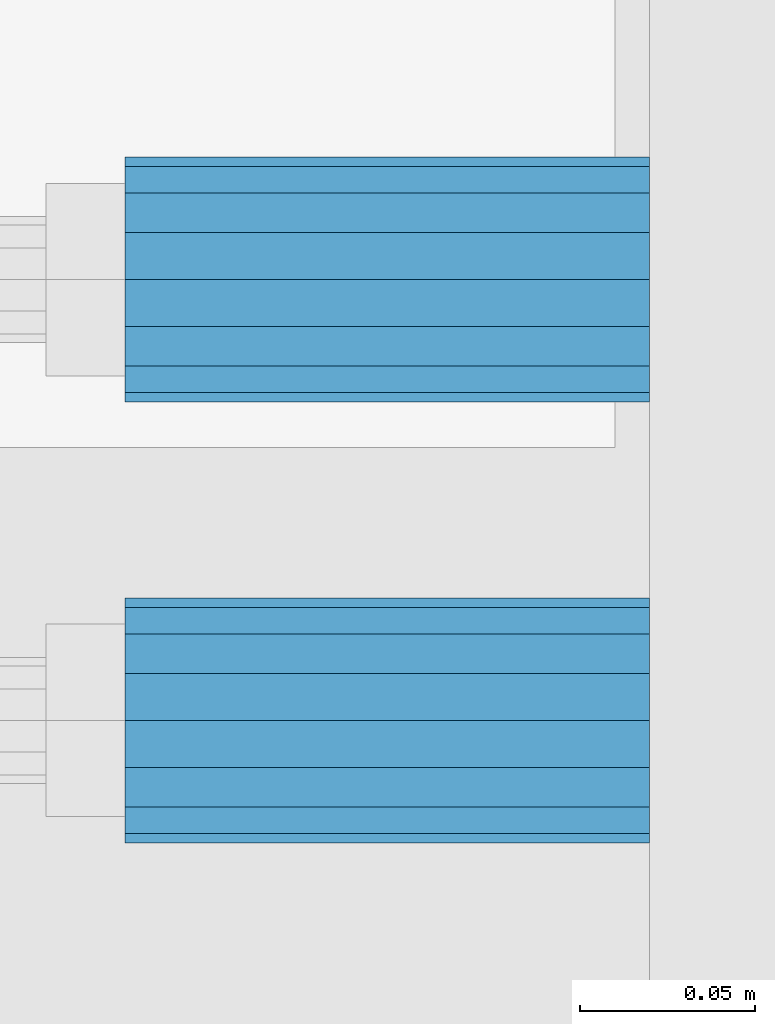
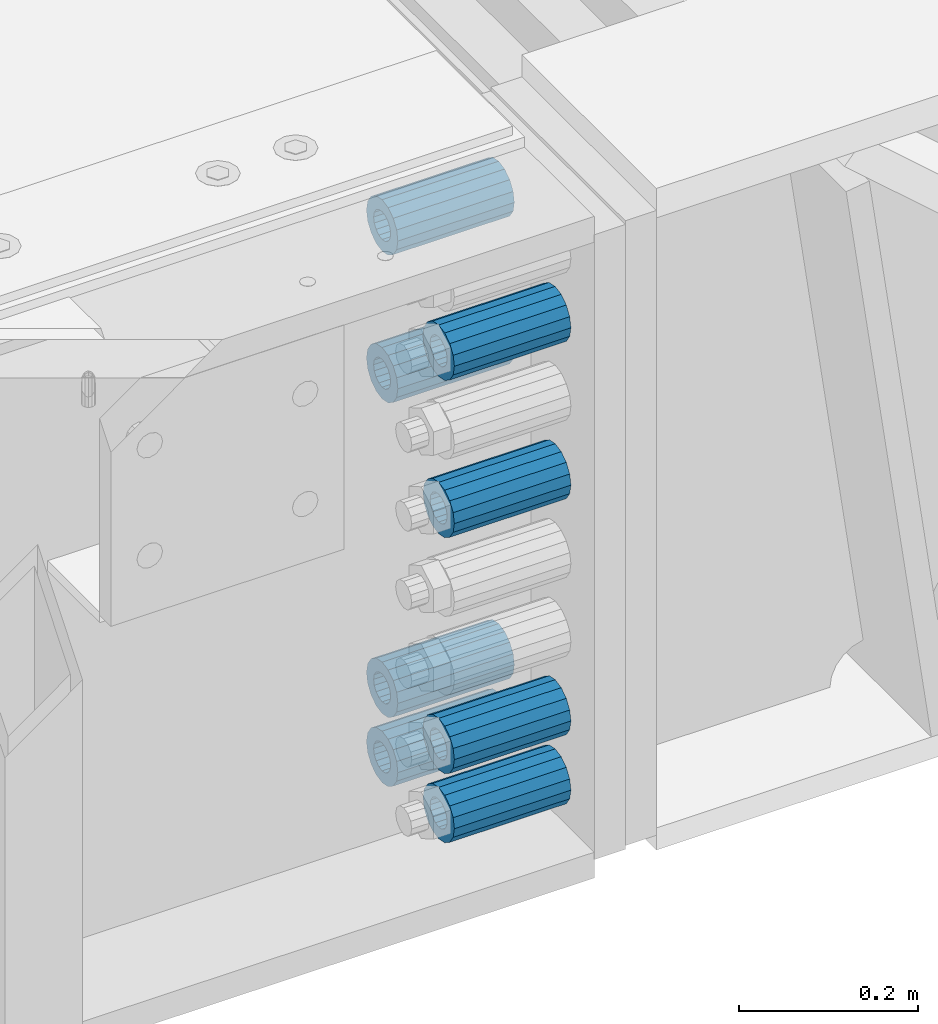
# One storey, part 158 of 242: 8 beams.
"""IFC2X3 building model written with IfcOpenShell, lengths in millimetres."""

from ifc_helpers import new_model, si_unit, frame, origin_with_axes, place, context, subcontext, project, spatial, faceted_brep, material, type_object, element, save


model = new_model("IFC2X3")

# Units and contexts
model_context = context("Model", 3, precision=1e-05, world=origin_with_axes())
body_context = subcontext(model_context, "Body", "Model", "MODEL_VIEW")
ifc_project = project(units=[si_unit("LENGTHUNIT", "METRE", prefix="MILLI"), si_unit("AREAUNIT", "SQUARE_METRE"), si_unit("VOLUMEUNIT", "CUBIC_METRE"), si_unit("MASSUNIT", "GRAM", prefix="KILO"), si_unit("TIMEUNIT", "SECOND"), si_unit("PLANEANGLEUNIT", "RADIAN"), si_unit("SOLIDANGLEUNIT", "STERADIAN"), si_unit("THERMODYNAMICTEMPERATUREUNIT", "DEGREE_CELSIUS"), si_unit("LUMINOUSINTENSITYUNIT", "LUMEN")], contexts=[model_context])

# Site, building, storey
site_placement = place(None, origin_with_axes())
site = spatial("IfcSite", under=ifc_project, at=site_placement, CompositionType="ELEMENT")
building_placement = place(site_placement, origin_with_axes())
building = spatial("IfcBuilding", under=site, at=building_placement, Name="Standard", CompositionType="ELEMENT")
storey_placement = place(building_placement, origin_with_axes())
storey = spatial("IfcBuildingStorey", under=building, at=storey_placement, Name="Undefined", CompositionType="ELEMENT", Elevation=0.0)

# Beams
ifc_material = material()
beam_type = type_object("IfcBeamType", PredefinedType="NOTDEFINED")
beam_1_placement = place(storey_placement, frame((-22210.0, -23937.0, -290.0), z_axis=(0.0, 0.0, 1.0), x_axis=(1.0, 0.0, 0.0)))
element("IfcBeam", 1, at=beam_1_placement, inside=storey, type_object=beam_type, material=ifc_material, context=body_context, shape_type="Brep", body=[
    faceted_brep([(1.33248249767348e-07, -19.0000000004493, -6.26823748461902e-09), (0.0, -17.5537111177146, 7.27098521493673), (150.0, -17.5537111177146, 7.27098521493673), (150.0, -19.0, 0.0), (0.0, -13.4350288425449, 13.4350288425444), (150.0, -13.4350288425449, 13.4350288425444), (0.0, -7.27098521493826, 17.5537111177144), (150.0, -7.27098521493826, 17.5537111177144), (-6.29370333626866e-09, -4.49290382675827e-10, 18.9999999937318), (150.0, 0.0, 19.0), (0.0, 7.27098521493826, 17.5537111177144), (150.0, 7.27098521493826, 17.5537111177144), (0.0, 13.4350288425449, 13.4350288425444), (150.0, 13.4350288425449, 13.4350288425444), (0.0, 17.5537111177146, 7.2709852149367), (150.0, 17.5537111177146, 7.2709852149367), (-1.31243723444641e-07, 18.9999999995507, -6.26823748461902e-09), (150.0, 19.0, 0.0), (0.0, 17.5537111177146, -7.2709852149367), (150.0, 17.5537111177146, -7.2709852149367), (0.0, 13.4350288425449, -13.4350288425444), (150.0, 13.4350288425449, -13.4350288425444), (0.0, 7.27098521493826, -17.5537111177144), (150.0, 7.27098521493826, -17.5537111177144), (8.2982296589762e-09, -4.49290382675827e-10, -19.0000000062719), (150.0, 0.0, -19.0), (0.0, -7.27098521493826, -17.5537111177144), (150.0, -7.27098521493826, -17.5537111177144), (0.0, -13.4350288425449, -13.4350288425444), (150.0, -13.4350288425449, -13.4350288425444), (0.0, -17.5537111177146, -7.2709852149367), (150.0, -17.5537111177146, -7.2709852149367), (-3.63797880709171e-12, -35.0, 0.0), (-3.63797880709171e-12, -32.335783637895, -13.3939201327812), (150.0, -32.3357836378964, -13.3939201327782), (150.0, -35.0, 0.0), (0.0, -24.7487373415292, -24.7487373415315), (150.0, -24.7487373415279, -24.7487373415292), (0.0, -13.3939201327782, -32.3357836378964), (150.0, -13.3939201327776, -32.335783637895), (0.0, 0.0, -35.0000000000036), (150.0, 0.0, -35.0), (0.0, 13.3939201327782, -32.3357836378964), (150.0, 13.3939201327776, -32.335783637895), (0.0, 24.7487373415292, -24.7487373415315), (150.0, 24.7487373415279, -24.7487373415292), (-3.63797880709171e-12, 32.335783637895, -13.3939201327812), (150.0, 32.3357836378964, -13.3939201327781), (-3.63797880709171e-12, 35.0, 0.0), (150.0, 35.0, 0.0), (-7.27595761418343e-12, 32.335783637895, 13.3939201327739), (150.0, 32.3357836378964, 13.3939201327781), (-7.27595761418343e-12, 24.7487373415292, 24.7487373415242), (150.0, 24.7487373415279, 24.7487373415292), (-7.27595761418343e-12, 13.3939201327781, 32.3357836378891), (150.0, 13.3939201327776, 32.335783637895), (-1.09139364212751e-11, 0.0, 34.9999999999964), (150.0, 0.0, 35.0), (-7.27595761418343e-12, -13.3939201327781, 32.3357836378891), (150.0, -13.3939201327776, 32.335783637895), (-7.27595761418343e-12, -24.7487373415292, 24.7487373415242), (150.0, -24.7487373415279, 24.7487373415292), (-7.27595761418343e-12, -32.335783637895, 13.3939201327739), (150.0, -32.3357836378964, 13.3939201327781)], [[[0, 1, 2, 3]], [[1, 4, 5, 2]], [[4, 6, 7, 5]], [[6, 8, 9, 7]], [[8, 10, 11, 9]], [[10, 12, 13, 11]], [[12, 14, 15, 13]], [[14, 16, 17, 15]], [[16, 18, 19, 17]], [[18, 20, 21, 19]], [[20, 22, 23, 21]], [[22, 24, 25, 23]], [[24, 26, 27, 25]], [[26, 28, 29, 27]], [[28, 30, 31, 29]], [[30, 0, 3, 31]], [[32, 33, 34, 35]], [[33, 36, 37, 34]], [[36, 38, 39, 37]], [[38, 40, 41, 39]], [[40, 42, 43, 41]], [[42, 44, 45, 43]], [[44, 46, 47, 45]], [[46, 48, 49, 47]], [[48, 50, 51, 49]], [[50, 52, 53, 51]], [[52, 54, 55, 53]], [[54, 56, 57, 55]], [[56, 58, 59, 57]], [[58, 60, 61, 59]], [[60, 62, 63, 61]], [[62, 32, 35, 63]], [[37, 39, 41, 43, 45, 47, 49, 51, 53, 55, 57, 59, 61, 63, 35, 34], [5, 7, 9, 11, 13, 15, 17, 19, 21, 23, 25, 27, 29, 31, 3, 2]], [[62, 60, 58, 56, 54, 52, 50, 48, 46, 44, 42, 40, 38, 36, 33, 32], [30, 28, 26, 24, 22, 20, 18, 16, 14, 12, 10, 8, 6, 4, 1, 0]]]),
])
beam_2_placement = place(storey_placement, frame((-22210.0, -23937.0, -718.0), z_axis=(0.0, 0.0, 1.0), x_axis=(1.0, 0.0, 0.0)))
element("IfcBeam", 2, at=beam_2_placement, inside=storey, type_object=beam_type, material=ifc_material, context=body_context, shape_type="Brep", body=[
    faceted_brep([(1.33248249767348e-07, -19.0000000004493, -6.26823748461902e-09), (0.0, -17.5537111177146, 7.27098521493673), (150.0, -17.5537111177146, 7.27098521493673), (150.0, -19.0, 0.0), (0.0, -13.4350288425449, 13.4350288425444), (150.0, -13.4350288425449, 13.4350288425444), (0.0, -7.27098521493826, 17.5537111177144), (150.0, -7.27098521493826, 17.5537111177144), (-6.29370333626866e-09, -4.49290382675827e-10, 18.9999999937318), (150.0, 0.0, 19.0), (0.0, 7.27098521493826, 17.5537111177144), (150.0, 7.27098521493826, 17.5537111177144), (0.0, 13.4350288425449, 13.4350288425444), (150.0, 13.4350288425449, 13.4350288425444), (0.0, 17.5537111177146, 7.2709852149367), (150.0, 17.5537111177146, 7.2709852149367), (-1.31243723444641e-07, 18.9999999995507, -6.26823748461902e-09), (150.0, 19.0, 0.0), (0.0, 17.5537111177146, -7.2709852149367), (150.0, 17.5537111177146, -7.2709852149367), (0.0, 13.4350288425449, -13.4350288425444), (150.0, 13.4350288425449, -13.4350288425444), (0.0, 7.27098521493826, -17.5537111177144), (150.0, 7.27098521493826, -17.5537111177144), (8.2982296589762e-09, -4.49290382675827e-10, -19.0000000062719), (150.0, 0.0, -19.0), (0.0, -7.27098521493826, -17.5537111177144), (150.0, -7.27098521493826, -17.5537111177144), (0.0, -13.4350288425449, -13.4350288425444), (150.0, -13.4350288425449, -13.4350288425444), (0.0, -17.5537111177146, -7.2709852149367), (150.0, -17.5537111177146, -7.2709852149367), (-3.63797880709171e-12, -35.0, 0.0), (-3.63797880709171e-12, -32.335783637895, -13.3939201327812), (150.0, -32.3357836378964, -13.3939201327782), (150.0, -35.0, 0.0), (0.0, -24.7487373415292, -24.7487373415315), (150.0, -24.7487373415279, -24.7487373415292), (0.0, -13.3939201327782, -32.3357836378964), (150.0, -13.3939201327776, -32.335783637895), (0.0, 0.0, -35.0000000000036), (150.0, 0.0, -35.0), (0.0, 13.3939201327782, -32.3357836378964), (150.0, 13.3939201327776, -32.335783637895), (0.0, 24.7487373415292, -24.7487373415315), (150.0, 24.7487373415279, -24.7487373415292), (-3.63797880709171e-12, 32.335783637895, -13.3939201327812), (150.0, 32.3357836378964, -13.3939201327781), (-3.63797880709171e-12, 35.0, 0.0), (150.0, 35.0, 0.0), (-7.27595761418343e-12, 32.335783637895, 13.3939201327739), (150.0, 32.3357836378964, 13.3939201327781), (-7.27595761418343e-12, 24.7487373415292, 24.7487373415242), (150.0, 24.7487373415279, 24.7487373415292), (-7.27595761418343e-12, 13.3939201327781, 32.3357836378891), (150.0, 13.3939201327776, 32.335783637895), (-1.09139364212751e-11, 0.0, 34.9999999999964), (150.0, 0.0, 35.0), (-7.27595761418343e-12, -13.3939201327781, 32.3357836378891), (150.0, -13.3939201327776, 32.335783637895), (-7.27595761418343e-12, -24.7487373415292, 24.7487373415242), (150.0, -24.7487373415279, 24.7487373415292), (-7.27595761418343e-12, -32.335783637895, 13.3939201327739), (150.0, -32.3357836378964, 13.3939201327781)], [[[0, 1, 2, 3]], [[1, 4, 5, 2]], [[4, 6, 7, 5]], [[6, 8, 9, 7]], [[8, 10, 11, 9]], [[10, 12, 13, 11]], [[12, 14, 15, 13]], [[14, 16, 17, 15]], [[16, 18, 19, 17]], [[18, 20, 21, 19]], [[20, 22, 23, 21]], [[22, 24, 25, 23]], [[24, 26, 27, 25]], [[26, 28, 29, 27]], [[28, 30, 31, 29]], [[30, 0, 3, 31]], [[32, 33, 34, 35]], [[33, 36, 37, 34]], [[36, 38, 39, 37]], [[38, 40, 41, 39]], [[40, 42, 43, 41]], [[42, 44, 45, 43]], [[44, 46, 47, 45]], [[46, 48, 49, 47]], [[48, 50, 51, 49]], [[50, 52, 53, 51]], [[52, 54, 55, 53]], [[54, 56, 57, 55]], [[56, 58, 59, 57]], [[58, 60, 61, 59]], [[60, 62, 63, 61]], [[62, 32, 35, 63]], [[37, 39, 41, 43, 45, 47, 49, 51, 53, 55, 57, 59, 61, 63, 35, 34], [5, 7, 9, 11, 13, 15, 17, 19, 21, 23, 25, 27, 29, 31, 3, 2]], [[62, 60, 58, 56, 54, 52, 50, 48, 46, 44, 42, 40, 38, 36, 33, 32], [30, 28, 26, 24, 22, 20, 18, 16, 14, 12, 10, 8, 6, 4, 1, 0]]]),
])
beam_3_placement = place(storey_placement, frame((-22210.0, -24063.0, -397.0), z_axis=(0.0, 0.0, 1.0), x_axis=(1.0, 0.0, 0.0)))
element("IfcBeam", 3, at=beam_3_placement, inside=storey, type_object=beam_type, material=ifc_material, context=body_context, shape_type="Brep", body=[
    faceted_brep([(1.33248249767348e-07, -19.0000000004493, -6.26823748461902e-09), (0.0, -17.5537111177146, 7.27098521493673), (150.0, -17.5537111177146, 7.27098521493673), (150.0, -19.0, 0.0), (0.0, -13.4350288425449, 13.4350288425444), (150.0, -13.4350288425449, 13.4350288425444), (0.0, -7.27098521493826, 17.5537111177144), (150.0, -7.27098521493826, 17.5537111177144), (-6.29370333626866e-09, -4.49290382675827e-10, 18.9999999937318), (150.0, 0.0, 19.0), (0.0, 7.27098521493826, 17.5537111177144), (150.0, 7.27098521493826, 17.5537111177144), (0.0, 13.4350288425449, 13.4350288425444), (150.0, 13.4350288425449, 13.4350288425444), (0.0, 17.5537111177146, 7.2709852149367), (150.0, 17.5537111177146, 7.2709852149367), (-1.31243723444641e-07, 18.9999999995507, -6.26823748461902e-09), (150.0, 19.0, 0.0), (0.0, 17.5537111177146, -7.2709852149367), (150.0, 17.5537111177146, -7.2709852149367), (0.0, 13.4350288425449, -13.4350288425444), (150.0, 13.4350288425449, -13.4350288425444), (0.0, 7.27098521493826, -17.5537111177144), (150.0, 7.27098521493826, -17.5537111177144), (8.2982296589762e-09, -4.49290382675827e-10, -19.0000000062719), (150.0, 0.0, -19.0), (0.0, -7.27098521493826, -17.5537111177144), (150.0, -7.27098521493826, -17.5537111177144), (0.0, -13.4350288425449, -13.4350288425444), (150.0, -13.4350288425449, -13.4350288425444), (0.0, -17.5537111177146, -7.2709852149367), (150.0, -17.5537111177146, -7.2709852149367), (-3.63797880709171e-12, -35.0, 0.0), (-3.63797880709171e-12, -32.335783637895, -13.3939201327812), (150.0, -32.3357836378964, -13.3939201327782), (150.0, -35.0, 0.0), (0.0, -24.7487373415292, -24.7487373415315), (150.0, -24.7487373415279, -24.7487373415292), (0.0, -13.3939201327782, -32.3357836378964), (150.0, -13.3939201327776, -32.335783637895), (0.0, 0.0, -35.0000000000036), (150.0, 0.0, -35.0), (0.0, 13.3939201327782, -32.3357836378964), (150.0, 13.3939201327776, -32.335783637895), (0.0, 24.7487373415292, -24.7487373415315), (150.0, 24.7487373415279, -24.7487373415292), (-3.63797880709171e-12, 32.335783637895, -13.3939201327812), (150.0, 32.3357836378964, -13.3939201327781), (-3.63797880709171e-12, 35.0, 0.0), (150.0, 35.0, 0.0), (-7.27595761418343e-12, 32.335783637895, 13.3939201327739), (150.0, 32.3357836378964, 13.3939201327781), (-7.27595761418343e-12, 24.7487373415292, 24.7487373415242), (150.0, 24.7487373415279, 24.7487373415292), (-7.27595761418343e-12, 13.3939201327781, 32.3357836378891), (150.0, 13.3939201327776, 32.335783637895), (-1.09139364212751e-11, 0.0, 34.9999999999964), (150.0, 0.0, 35.0), (-7.27595761418343e-12, -13.3939201327781, 32.3357836378891), (150.0, -13.3939201327776, 32.335783637895), (-7.27595761418343e-12, -24.7487373415292, 24.7487373415242), (150.0, -24.7487373415279, 24.7487373415292), (-7.27595761418343e-12, -32.335783637895, 13.3939201327739), (150.0, -32.3357836378964, 13.3939201327781)], [[[0, 1, 2, 3]], [[1, 4, 5, 2]], [[4, 6, 7, 5]], [[6, 8, 9, 7]], [[8, 10, 11, 9]], [[10, 12, 13, 11]], [[12, 14, 15, 13]], [[14, 16, 17, 15]], [[16, 18, 19, 17]], [[18, 20, 21, 19]], [[20, 22, 23, 21]], [[22, 24, 25, 23]], [[24, 26, 27, 25]], [[26, 28, 29, 27]], [[28, 30, 31, 29]], [[30, 0, 3, 31]], [[32, 33, 34, 35]], [[33, 36, 37, 34]], [[36, 38, 39, 37]], [[38, 40, 41, 39]], [[40, 42, 43, 41]], [[42, 44, 45, 43]], [[44, 46, 47, 45]], [[46, 48, 49, 47]], [[48, 50, 51, 49]], [[50, 52, 53, 51]], [[52, 54, 55, 53]], [[54, 56, 57, 55]], [[56, 58, 59, 57]], [[58, 60, 61, 59]], [[60, 62, 63, 61]], [[62, 32, 35, 63]], [[37, 39, 41, 43, 45, 47, 49, 51, 53, 55, 57, 59, 61, 63, 35, 34], [5, 7, 9, 11, 13, 15, 17, 19, 21, 23, 25, 27, 29, 31, 3, 2]], [[62, 60, 58, 56, 54, 52, 50, 48, 46, 44, 42, 40, 38, 36, 33, 32], [30, 28, 26, 24, 22, 20, 18, 16, 14, 12, 10, 8, 6, 4, 1, 0]]]),
])
beam_4_placement = place(storey_placement, frame((-22210.0, -23937.0, -89.0000000000001), z_axis=(0.0, 0.0, 1.0), x_axis=(1.0, 0.0, 0.0)))
element("IfcBeam", 4, at=beam_4_placement, inside=storey, type_object=beam_type, material=ifc_material, context=body_context, shape_type="Brep", body=[
    faceted_brep([(1.33248249767348e-07, -19.0000000004493, -6.26823748461902e-09), (0.0, -17.5537111177146, 7.27098521493673), (150.0, -17.5537111177146, 7.27098521493673), (150.0, -19.0, 0.0), (0.0, -13.4350288425449, 13.4350288425444), (150.0, -13.4350288425449, 13.4350288425444), (0.0, -7.27098521493826, 17.5537111177144), (150.0, -7.27098521493826, 17.5537111177144), (-6.29370333626866e-09, -4.49290382675827e-10, 18.9999999937318), (150.0, 0.0, 19.0), (0.0, 7.27098521493826, 17.5537111177144), (150.0, 7.27098521493826, 17.5537111177144), (0.0, 13.4350288425449, 13.4350288425444), (150.0, 13.4350288425449, 13.4350288425444), (0.0, 17.5537111177146, 7.2709852149367), (150.0, 17.5537111177146, 7.2709852149367), (-1.31243723444641e-07, 18.9999999995507, -6.26823748461902e-09), (150.0, 19.0, 0.0), (0.0, 17.5537111177146, -7.2709852149367), (150.0, 17.5537111177146, -7.2709852149367), (0.0, 13.4350288425449, -13.4350288425444), (150.0, 13.4350288425449, -13.4350288425444), (0.0, 7.27098521493826, -17.5537111177144), (150.0, 7.27098521493826, -17.5537111177144), (8.2982296589762e-09, -4.49290382675827e-10, -19.0000000062719), (150.0, 0.0, -19.0), (0.0, -7.27098521493826, -17.5537111177144), (150.0, -7.27098521493826, -17.5537111177144), (0.0, -13.4350288425449, -13.4350288425444), (150.0, -13.4350288425449, -13.4350288425444), (0.0, -17.5537111177146, -7.2709852149367), (150.0, -17.5537111177146, -7.2709852149367), (-3.63797880709171e-12, -35.0, 0.0), (-3.63797880709171e-12, -32.335783637895, -13.3939201327812), (150.0, -32.3357836378964, -13.3939201327782), (150.0, -35.0, 0.0), (0.0, -24.7487373415292, -24.7487373415315), (150.0, -24.7487373415279, -24.7487373415292), (0.0, -13.3939201327782, -32.3357836378964), (150.0, -13.3939201327776, -32.335783637895), (0.0, 0.0, -35.0000000000036), (150.0, 0.0, -35.0), (0.0, 13.3939201327782, -32.3357836378964), (150.0, 13.3939201327776, -32.335783637895), (0.0, 24.7487373415292, -24.7487373415315), (150.0, 24.7487373415279, -24.7487373415292), (-3.63797880709171e-12, 32.335783637895, -13.3939201327812), (150.0, 32.3357836378964, -13.3939201327781), (-3.63797880709171e-12, 35.0, 0.0), (150.0, 35.0, 0.0), (-7.27595761418343e-12, 32.335783637895, 13.3939201327739), (150.0, 32.3357836378964, 13.3939201327781), (-7.27595761418343e-12, 24.7487373415292, 24.7487373415242), (150.0, 24.7487373415279, 24.7487373415292), (-7.27595761418343e-12, 13.3939201327781, 32.3357836378891), (150.0, 13.3939201327776, 32.335783637895), (-1.09139364212751e-11, 0.0, 34.9999999999964), (150.0, 0.0, 35.0), (-7.27595761418343e-12, -13.3939201327781, 32.3357836378891), (150.0, -13.3939201327776, 32.335783637895), (-7.27595761418343e-12, -24.7487373415292, 24.7487373415242), (150.0, -24.7487373415279, 24.7487373415292), (-7.27595761418343e-12, -32.335783637895, 13.3939201327739), (150.0, -32.3357836378964, 13.3939201327781)], [[[0, 1, 2, 3]], [[1, 4, 5, 2]], [[4, 6, 7, 5]], [[6, 8, 9, 7]], [[8, 10, 11, 9]], [[10, 12, 13, 11]], [[12, 14, 15, 13]], [[14, 16, 17, 15]], [[16, 18, 19, 17]], [[18, 20, 21, 19]], [[20, 22, 23, 21]], [[22, 24, 25, 23]], [[24, 26, 27, 25]], [[26, 28, 29, 27]], [[28, 30, 31, 29]], [[30, 0, 3, 31]], [[32, 33, 34, 35]], [[33, 36, 37, 34]], [[36, 38, 39, 37]], [[38, 40, 41, 39]], [[40, 42, 43, 41]], [[42, 44, 45, 43]], [[44, 46, 47, 45]], [[46, 48, 49, 47]], [[48, 50, 51, 49]], [[50, 52, 53, 51]], [[52, 54, 55, 53]], [[54, 56, 57, 55]], [[56, 58, 59, 57]], [[58, 60, 61, 59]], [[60, 62, 63, 61]], [[62, 32, 35, 63]], [[37, 39, 41, 43, 45, 47, 49, 51, 53, 55, 57, 59, 61, 63, 35, 34], [5, 7, 9, 11, 13, 15, 17, 19, 21, 23, 25, 27, 29, 31, 3, 2]], [[62, 60, 58, 56, 54, 52, 50, 48, 46, 44, 42, 40, 38, 36, 33, 32], [30, 28, 26, 24, 22, 20, 18, 16, 14, 12, 10, 8, 6, 4, 1, 0]]]),
])
beam_5_placement = place(storey_placement, frame((-22210.0, -24063.0, -183.0), z_axis=(0.0, 0.0, 1.0), x_axis=(1.0, 0.0, 0.0)))
element("IfcBeam", 5, at=beam_5_placement, inside=storey, type_object=beam_type, material=ifc_material, context=body_context, shape_type="Brep", body=[
    faceted_brep([(1.33248249767348e-07, -19.0000000004493, -6.26823748461902e-09), (0.0, -17.5537111177146, 7.27098521493673), (150.0, -17.5537111177146, 7.27098521493673), (150.0, -19.0, 0.0), (0.0, -13.4350288425449, 13.4350288425444), (150.0, -13.4350288425449, 13.4350288425444), (0.0, -7.27098521493826, 17.5537111177144), (150.0, -7.27098521493826, 17.5537111177144), (-6.29370333626866e-09, -4.49290382675827e-10, 18.9999999937318), (150.0, 0.0, 19.0), (0.0, 7.27098521493826, 17.5537111177144), (150.0, 7.27098521493826, 17.5537111177144), (0.0, 13.4350288425449, 13.4350288425444), (150.0, 13.4350288425449, 13.4350288425444), (0.0, 17.5537111177146, 7.2709852149367), (150.0, 17.5537111177146, 7.2709852149367), (-1.31243723444641e-07, 18.9999999995507, -6.26823748461902e-09), (150.0, 19.0, 0.0), (0.0, 17.5537111177146, -7.2709852149367), (150.0, 17.5537111177146, -7.2709852149367), (0.0, 13.4350288425449, -13.4350288425444), (150.0, 13.4350288425449, -13.4350288425444), (0.0, 7.27098521493826, -17.5537111177144), (150.0, 7.27098521493826, -17.5537111177144), (8.2982296589762e-09, -4.49290382675827e-10, -19.0000000062719), (150.0, 0.0, -19.0), (0.0, -7.27098521493826, -17.5537111177144), (150.0, -7.27098521493826, -17.5537111177144), (0.0, -13.4350288425449, -13.4350288425444), (150.0, -13.4350288425449, -13.4350288425444), (0.0, -17.5537111177146, -7.2709852149367), (150.0, -17.5537111177146, -7.2709852149367), (-3.63797880709171e-12, -35.0, 0.0), (-3.63797880709171e-12, -32.335783637895, -13.3939201327812), (150.0, -32.3357836378964, -13.3939201327782), (150.0, -35.0, 0.0), (0.0, -24.7487373415292, -24.7487373415315), (150.0, -24.7487373415279, -24.7487373415292), (0.0, -13.3939201327782, -32.3357836378964), (150.0, -13.3939201327776, -32.335783637895), (0.0, 0.0, -35.0000000000036), (150.0, 0.0, -35.0), (0.0, 13.3939201327782, -32.3357836378964), (150.0, 13.3939201327776, -32.335783637895), (0.0, 24.7487373415292, -24.7487373415315), (150.0, 24.7487373415279, -24.7487373415292), (-3.63797880709171e-12, 32.335783637895, -13.3939201327812), (150.0, 32.3357836378964, -13.3939201327781), (-3.63797880709171e-12, 35.0, 0.0), (150.0, 35.0, 0.0), (-7.27595761418343e-12, 32.335783637895, 13.3939201327739), (150.0, 32.3357836378964, 13.3939201327781), (-7.27595761418343e-12, 24.7487373415292, 24.7487373415242), (150.0, 24.7487373415279, 24.7487373415292), (-7.27595761418343e-12, 13.3939201327781, 32.3357836378891), (150.0, 13.3939201327776, 32.335783637895), (-1.09139364212751e-11, 0.0, 34.9999999999964), (150.0, 0.0, 35.0), (-7.27595761418343e-12, -13.3939201327781, 32.3357836378891), (150.0, -13.3939201327776, 32.335783637895), (-7.27595761418343e-12, -24.7487373415292, 24.7487373415242), (150.0, -24.7487373415279, 24.7487373415292), (-7.27595761418343e-12, -32.335783637895, 13.3939201327739), (150.0, -32.3357836378964, 13.3939201327781)], [[[0, 1, 2, 3]], [[1, 4, 5, 2]], [[4, 6, 7, 5]], [[6, 8, 9, 7]], [[8, 10, 11, 9]], [[10, 12, 13, 11]], [[12, 14, 15, 13]], [[14, 16, 17, 15]], [[16, 18, 19, 17]], [[18, 20, 21, 19]], [[20, 22, 23, 21]], [[22, 24, 25, 23]], [[24, 26, 27, 25]], [[26, 28, 29, 27]], [[28, 30, 31, 29]], [[30, 0, 3, 31]], [[32, 33, 34, 35]], [[33, 36, 37, 34]], [[36, 38, 39, 37]], [[38, 40, 41, 39]], [[40, 42, 43, 41]], [[42, 44, 45, 43]], [[44, 46, 47, 45]], [[46, 48, 49, 47]], [[48, 50, 51, 49]], [[50, 52, 53, 51]], [[52, 54, 55, 53]], [[54, 56, 57, 55]], [[56, 58, 59, 57]], [[58, 60, 61, 59]], [[60, 62, 63, 61]], [[62, 32, 35, 63]], [[37, 39, 41, 43, 45, 47, 49, 51, 53, 55, 57, 59, 61, 63, 35, 34], [5, 7, 9, 11, 13, 15, 17, 19, 21, 23, 25, 27, 29, 31, 3, 2]], [[62, 60, 58, 56, 54, 52, 50, 48, 46, 44, 42, 40, 38, 36, 33, 32], [30, 28, 26, 24, 22, 20, 18, 16, 14, 12, 10, 8, 6, 4, 1, 0]]]),
])
beam_6_placement = place(storey_placement, frame((-22210.0, -24063.0, -718.0), z_axis=(0.0, 0.0, 1.0), x_axis=(1.0, 0.0, 0.0)))
element("IfcBeam", 6, at=beam_6_placement, inside=storey, type_object=beam_type, material=ifc_material, context=body_context, shape_type="Brep", body=[
    faceted_brep([(1.33248249767348e-07, -19.0000000004493, -6.26823748461902e-09), (0.0, -17.5537111177146, 7.27098521493673), (150.0, -17.5537111177146, 7.27098521493673), (150.0, -19.0, 0.0), (0.0, -13.4350288425449, 13.4350288425444), (150.0, -13.4350288425449, 13.4350288425444), (0.0, -7.27098521493826, 17.5537111177144), (150.0, -7.27098521493826, 17.5537111177144), (-6.29370333626866e-09, -4.49290382675827e-10, 18.9999999937318), (150.0, 0.0, 19.0), (0.0, 7.27098521493826, 17.5537111177144), (150.0, 7.27098521493826, 17.5537111177144), (0.0, 13.4350288425449, 13.4350288425444), (150.0, 13.4350288425449, 13.4350288425444), (0.0, 17.5537111177146, 7.2709852149367), (150.0, 17.5537111177146, 7.2709852149367), (-1.31243723444641e-07, 18.9999999995507, -6.26823748461902e-09), (150.0, 19.0, 0.0), (0.0, 17.5537111177146, -7.2709852149367), (150.0, 17.5537111177146, -7.2709852149367), (0.0, 13.4350288425449, -13.4350288425444), (150.0, 13.4350288425449, -13.4350288425444), (0.0, 7.27098521493826, -17.5537111177144), (150.0, 7.27098521493826, -17.5537111177144), (8.2982296589762e-09, -4.49290382675827e-10, -19.0000000062719), (150.0, 0.0, -19.0), (0.0, -7.27098521493826, -17.5537111177144), (150.0, -7.27098521493826, -17.5537111177144), (0.0, -13.4350288425449, -13.4350288425444), (150.0, -13.4350288425449, -13.4350288425444), (0.0, -17.5537111177146, -7.2709852149367), (150.0, -17.5537111177146, -7.2709852149367), (-3.63797880709171e-12, -35.0, 0.0), (-3.63797880709171e-12, -32.335783637895, -13.3939201327812), (150.0, -32.3357836378964, -13.3939201327782), (150.0, -35.0, 0.0), (0.0, -24.7487373415292, -24.7487373415315), (150.0, -24.7487373415279, -24.7487373415292), (0.0, -13.3939201327782, -32.3357836378964), (150.0, -13.3939201327776, -32.335783637895), (0.0, 0.0, -35.0000000000036), (150.0, 0.0, -35.0), (0.0, 13.3939201327782, -32.3357836378964), (150.0, 13.3939201327776, -32.335783637895), (0.0, 24.7487373415292, -24.7487373415315), (150.0, 24.7487373415279, -24.7487373415292), (-3.63797880709171e-12, 32.335783637895, -13.3939201327812), (150.0, 32.3357836378964, -13.3939201327781), (-3.63797880709171e-12, 35.0, 0.0), (150.0, 35.0, 0.0), (-7.27595761418343e-12, 32.335783637895, 13.3939201327739), (150.0, 32.3357836378964, 13.3939201327781), (-7.27595761418343e-12, 24.7487373415292, 24.7487373415242), (150.0, 24.7487373415279, 24.7487373415292), (-7.27595761418343e-12, 13.3939201327781, 32.3357836378891), (150.0, 13.3939201327776, 32.335783637895), (-1.09139364212751e-11, 0.0, 34.9999999999964), (150.0, 0.0, 35.0), (-7.27595761418343e-12, -13.3939201327781, 32.3357836378891), (150.0, -13.3939201327776, 32.335783637895), (-7.27595761418343e-12, -24.7487373415292, 24.7487373415242), (150.0, -24.7487373415279, 24.7487373415292), (-7.27595761418343e-12, -32.335783637895, 13.3939201327739), (150.0, -32.3357836378964, 13.3939201327781)], [[[0, 1, 2, 3]], [[1, 4, 5, 2]], [[4, 6, 7, 5]], [[6, 8, 9, 7]], [[8, 10, 11, 9]], [[10, 12, 13, 11]], [[12, 14, 15, 13]], [[14, 16, 17, 15]], [[16, 18, 19, 17]], [[18, 20, 21, 19]], [[20, 22, 23, 21]], [[22, 24, 25, 23]], [[24, 26, 27, 25]], [[26, 28, 29, 27]], [[28, 30, 31, 29]], [[30, 0, 3, 31]], [[32, 33, 34, 35]], [[33, 36, 37, 34]], [[36, 38, 39, 37]], [[38, 40, 41, 39]], [[40, 42, 43, 41]], [[42, 44, 45, 43]], [[44, 46, 47, 45]], [[46, 48, 49, 47]], [[48, 50, 51, 49]], [[50, 52, 53, 51]], [[52, 54, 55, 53]], [[54, 56, 57, 55]], [[56, 58, 59, 57]], [[58, 60, 61, 59]], [[60, 62, 63, 61]], [[62, 32, 35, 63]], [[37, 39, 41, 43, 45, 47, 49, 51, 53, 55, 57, 59, 61, 63, 35, 34], [5, 7, 9, 11, 13, 15, 17, 19, 21, 23, 25, 27, 29, 31, 3, 2]], [[62, 60, 58, 56, 54, 52, 50, 48, 46, 44, 42, 40, 38, 36, 33, 32], [30, 28, 26, 24, 22, 20, 18, 16, 14, 12, 10, 8, 6, 4, 1, 0]]]),
])
beam_7_placement = place(storey_placement, frame((-22210.0, -23937.0, -812.0), z_axis=(0.0, 0.0, 1.0), x_axis=(1.0, 0.0, 0.0)))
element("IfcBeam", 7, at=beam_7_placement, inside=storey, type_object=beam_type, material=ifc_material, context=body_context, shape_type="Brep", body=[
    faceted_brep([(1.33248249767348e-07, -19.0000000004493, -6.26823748461902e-09), (0.0, -17.5537111177146, 7.27098521493673), (150.0, -17.5537111177146, 7.27098521493673), (150.0, -19.0, 0.0), (0.0, -13.4350288425449, 13.4350288425444), (150.0, -13.4350288425449, 13.4350288425444), (0.0, -7.27098521493826, 17.5537111177144), (150.0, -7.27098521493826, 17.5537111177144), (-6.29370333626866e-09, -4.49290382675827e-10, 18.9999999937318), (150.0, 0.0, 19.0), (0.0, 7.27098521493826, 17.5537111177144), (150.0, 7.27098521493826, 17.5537111177144), (0.0, 13.4350288425449, 13.4350288425444), (150.0, 13.4350288425449, 13.4350288425444), (0.0, 17.5537111177146, 7.2709852149367), (150.0, 17.5537111177146, 7.2709852149367), (-1.31243723444641e-07, 18.9999999995507, -6.26823748461902e-09), (150.0, 19.0, 0.0), (0.0, 17.5537111177146, -7.2709852149367), (150.0, 17.5537111177146, -7.2709852149367), (0.0, 13.4350288425449, -13.4350288425444), (150.0, 13.4350288425449, -13.4350288425444), (0.0, 7.27098521493826, -17.5537111177144), (150.0, 7.27098521493826, -17.5537111177144), (8.2982296589762e-09, -4.49290382675827e-10, -19.0000000062719), (150.0, 0.0, -19.0), (0.0, -7.27098521493826, -17.5537111177144), (150.0, -7.27098521493826, -17.5537111177144), (0.0, -13.4350288425449, -13.4350288425444), (150.0, -13.4350288425449, -13.4350288425444), (0.0, -17.5537111177146, -7.2709852149367), (150.0, -17.5537111177146, -7.2709852149367), (-3.63797880709171e-12, -35.0, 0.0), (-3.63797880709171e-12, -32.335783637895, -13.3939201327812), (150.0, -32.3357836378964, -13.3939201327782), (150.0, -35.0, 0.0), (0.0, -24.7487373415292, -24.7487373415315), (150.0, -24.7487373415279, -24.7487373415292), (0.0, -13.3939201327782, -32.3357836378964), (150.0, -13.3939201327776, -32.335783637895), (0.0, 0.0, -35.0000000000036), (150.0, 0.0, -35.0), (0.0, 13.3939201327782, -32.3357836378964), (150.0, 13.3939201327776, -32.335783637895), (0.0, 24.7487373415292, -24.7487373415315), (150.0, 24.7487373415279, -24.7487373415292), (-3.63797880709171e-12, 32.335783637895, -13.3939201327812), (150.0, 32.3357836378964, -13.3939201327781), (-3.63797880709171e-12, 35.0, 0.0), (150.0, 35.0, 0.0), (-7.27595761418343e-12, 32.335783637895, 13.3939201327739), (150.0, 32.3357836378964, 13.3939201327781), (-7.27595761418343e-12, 24.7487373415292, 24.7487373415242), (150.0, 24.7487373415279, 24.7487373415292), (-7.27595761418343e-12, 13.3939201327781, 32.3357836378891), (150.0, 13.3939201327776, 32.335783637895), (-1.09139364212751e-11, 0.0, 34.9999999999964), (150.0, 0.0, 35.0), (-7.27595761418343e-12, -13.3939201327781, 32.3357836378891), (150.0, -13.3939201327776, 32.335783637895), (-7.27595761418343e-12, -24.7487373415292, 24.7487373415242), (150.0, -24.7487373415279, 24.7487373415292), (-7.27595761418343e-12, -32.335783637895, 13.3939201327739), (150.0, -32.3357836378964, 13.3939201327781)], [[[0, 1, 2, 3]], [[1, 4, 5, 2]], [[4, 6, 7, 5]], [[6, 8, 9, 7]], [[8, 10, 11, 9]], [[10, 12, 13, 11]], [[12, 14, 15, 13]], [[14, 16, 17, 15]], [[16, 18, 19, 17]], [[18, 20, 21, 19]], [[20, 22, 23, 21]], [[22, 24, 25, 23]], [[24, 26, 27, 25]], [[26, 28, 29, 27]], [[28, 30, 31, 29]], [[30, 0, 3, 31]], [[32, 33, 34, 35]], [[33, 36, 37, 34]], [[36, 38, 39, 37]], [[38, 40, 41, 39]], [[40, 42, 43, 41]], [[42, 44, 45, 43]], [[44, 46, 47, 45]], [[46, 48, 49, 47]], [[48, 50, 51, 49]], [[50, 52, 53, 51]], [[52, 54, 55, 53]], [[54, 56, 57, 55]], [[56, 58, 59, 57]], [[58, 60, 61, 59]], [[60, 62, 63, 61]], [[62, 32, 35, 63]], [[37, 39, 41, 43, 45, 47, 49, 51, 53, 55, 57, 59, 61, 63, 35, 34], [5, 7, 9, 11, 13, 15, 17, 19, 21, 23, 25, 27, 29, 31, 3, 2]], [[62, 60, 58, 56, 54, 52, 50, 48, 46, 44, 42, 40, 38, 36, 33, 32], [30, 28, 26, 24, 22, 20, 18, 16, 14, 12, 10, 8, 6, 4, 1, 0]]]),
])
beam_8_placement = place(storey_placement, frame((-22210.0, -24063.0, -812.0), z_axis=(0.0, 0.0, 1.0), x_axis=(1.0, 0.0, 0.0)))
element("IfcBeam", 8, at=beam_8_placement, inside=storey, type_object=beam_type, material=ifc_material, context=body_context, shape_type="Brep", body=[
    faceted_brep([(1.33248249767348e-07, -19.0000000004493, -6.26823748461902e-09), (0.0, -17.5537111177146, 7.27098521493673), (150.0, -17.5537111177146, 7.27098521493673), (150.0, -19.0, 0.0), (0.0, -13.4350288425449, 13.4350288425444), (150.0, -13.4350288425449, 13.4350288425444), (0.0, -7.27098521493826, 17.5537111177144), (150.0, -7.27098521493826, 17.5537111177144), (-6.29370333626866e-09, -4.49290382675827e-10, 18.9999999937318), (150.0, 0.0, 19.0), (0.0, 7.27098521493826, 17.5537111177144), (150.0, 7.27098521493826, 17.5537111177144), (0.0, 13.4350288425449, 13.4350288425444), (150.0, 13.4350288425449, 13.4350288425444), (0.0, 17.5537111177146, 7.2709852149367), (150.0, 17.5537111177146, 7.2709852149367), (-1.31243723444641e-07, 18.9999999995507, -6.26823748461902e-09), (150.0, 19.0, 0.0), (0.0, 17.5537111177146, -7.2709852149367), (150.0, 17.5537111177146, -7.2709852149367), (0.0, 13.4350288425449, -13.4350288425444), (150.0, 13.4350288425449, -13.4350288425444), (0.0, 7.27098521493826, -17.5537111177144), (150.0, 7.27098521493826, -17.5537111177144), (8.2982296589762e-09, -4.49290382675827e-10, -19.0000000062719), (150.0, 0.0, -19.0), (0.0, -7.27098521493826, -17.5537111177144), (150.0, -7.27098521493826, -17.5537111177144), (0.0, -13.4350288425449, -13.4350288425444), (150.0, -13.4350288425449, -13.4350288425444), (0.0, -17.5537111177146, -7.2709852149367), (150.0, -17.5537111177146, -7.2709852149367), (-3.63797880709171e-12, -35.0, 0.0), (-3.63797880709171e-12, -32.335783637895, -13.3939201327812), (150.0, -32.3357836378964, -13.3939201327782), (150.0, -35.0, 0.0), (0.0, -24.7487373415292, -24.7487373415315), (150.0, -24.7487373415279, -24.7487373415292), (0.0, -13.3939201327782, -32.3357836378964), (150.0, -13.3939201327776, -32.335783637895), (0.0, 0.0, -35.0000000000036), (150.0, 0.0, -35.0), (0.0, 13.3939201327782, -32.3357836378964), (150.0, 13.3939201327776, -32.335783637895), (0.0, 24.7487373415292, -24.7487373415315), (150.0, 24.7487373415279, -24.7487373415292), (-3.63797880709171e-12, 32.335783637895, -13.3939201327812), (150.0, 32.3357836378964, -13.3939201327781), (-3.63797880709171e-12, 35.0, 0.0), (150.0, 35.0, 0.0), (-7.27595761418343e-12, 32.335783637895, 13.3939201327739), (150.0, 32.3357836378964, 13.3939201327781), (-7.27595761418343e-12, 24.7487373415292, 24.7487373415242), (150.0, 24.7487373415279, 24.7487373415292), (-7.27595761418343e-12, 13.3939201327781, 32.3357836378891), (150.0, 13.3939201327776, 32.335783637895), (-1.09139364212751e-11, 0.0, 34.9999999999964), (150.0, 0.0, 35.0), (-7.27595761418343e-12, -13.3939201327781, 32.3357836378891), (150.0, -13.3939201327776, 32.335783637895), (-7.27595761418343e-12, -24.7487373415292, 24.7487373415242), (150.0, -24.7487373415279, 24.7487373415292), (-7.27595761418343e-12, -32.335783637895, 13.3939201327739), (150.0, -32.3357836378964, 13.3939201327781)], [[[0, 1, 2, 3]], [[1, 4, 5, 2]], [[4, 6, 7, 5]], [[6, 8, 9, 7]], [[8, 10, 11, 9]], [[10, 12, 13, 11]], [[12, 14, 15, 13]], [[14, 16, 17, 15]], [[16, 18, 19, 17]], [[18, 20, 21, 19]], [[20, 22, 23, 21]], [[22, 24, 25, 23]], [[24, 26, 27, 25]], [[26, 28, 29, 27]], [[28, 30, 31, 29]], [[30, 0, 3, 31]], [[32, 33, 34, 35]], [[33, 36, 37, 34]], [[36, 38, 39, 37]], [[38, 40, 41, 39]], [[40, 42, 43, 41]], [[42, 44, 45, 43]], [[44, 46, 47, 45]], [[46, 48, 49, 47]], [[48, 50, 51, 49]], [[50, 52, 53, 51]], [[52, 54, 55, 53]], [[54, 56, 57, 55]], [[56, 58, 59, 57]], [[58, 60, 61, 59]], [[60, 62, 63, 61]], [[62, 32, 35, 63]], [[37, 39, 41, 43, 45, 47, 49, 51, 53, 55, 57, 59, 61, 63, 35, 34], [5, 7, 9, 11, 13, 15, 17, 19, 21, 23, 25, 27, 29, 31, 3, 2]], [[62, 60, 58, 56, 54, 52, 50, 48, 46, 44, 42, 40, 38, 36, 33, 32], [30, 28, 26, 24, 22, 20, 18, 16, 14, 12, 10, 8, 6, 4, 1, 0]]]),
])

save(model, "model.ifc")
